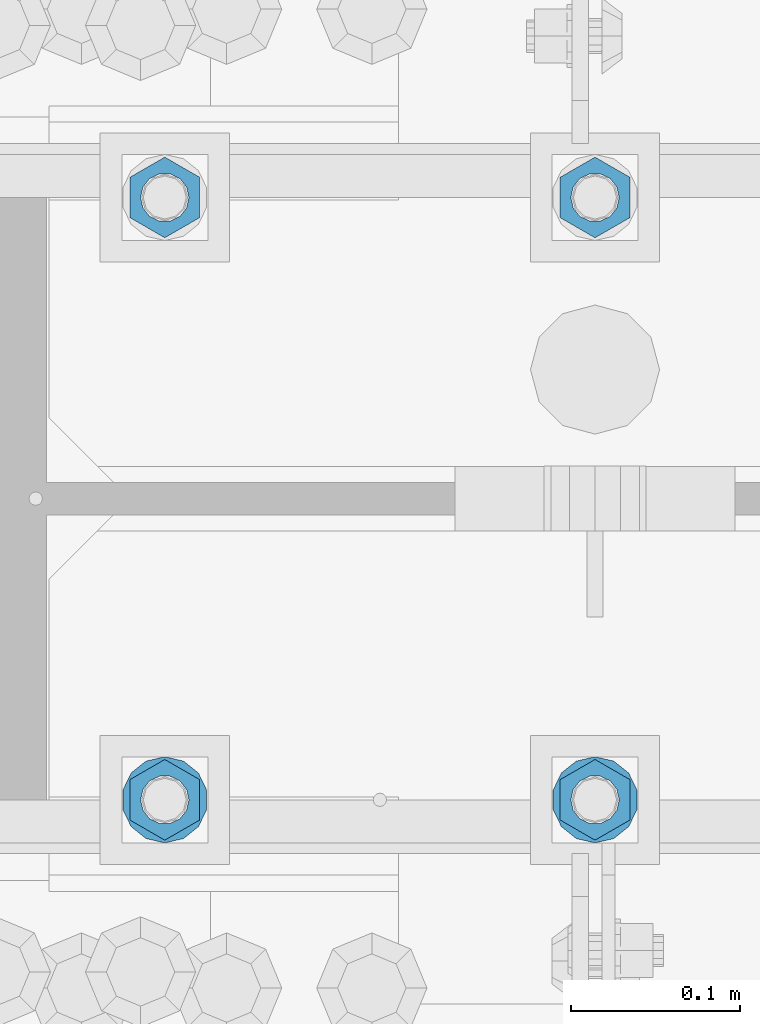
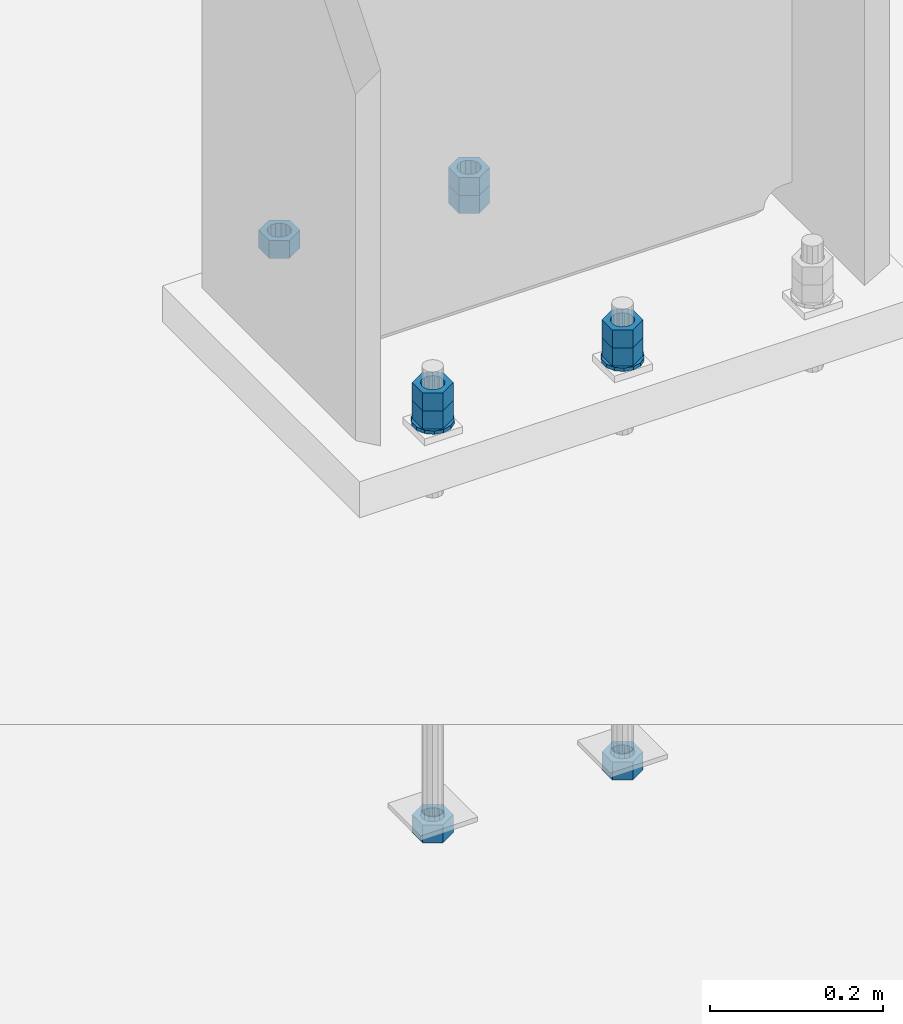
# One storey, part 1025 of 1763: 11 columns, 1 element without a shape of its own.
"""IFC2X3 building model written with IfcOpenShell, lengths in millimetres."""

from ifc_helpers import new_model, si_unit, frame, origin_with_axes, place, context, subcontext, project, spatial, faceted_brep, material, type_object, element, aggregate, save


model = new_model("IFC2X3")

# Units and contexts
model_context = context("Model", 3, precision=1e-05, world=origin_with_axes())
body_context = subcontext(model_context, "Body", "Model", "MODEL_VIEW")
ifc_project = project(units=[si_unit("LENGTHUNIT", "METRE", prefix="MILLI"), si_unit("AREAUNIT", "SQUARE_METRE"), si_unit("VOLUMEUNIT", "CUBIC_METRE"), si_unit("MASSUNIT", "GRAM", prefix="KILO"), si_unit("TIMEUNIT", "SECOND"), si_unit("PLANEANGLEUNIT", "RADIAN"), si_unit("SOLIDANGLEUNIT", "STERADIAN"), si_unit("THERMODYNAMICTEMPERATUREUNIT", "DEGREE_CELSIUS"), si_unit("LUMINOUSINTENSITYUNIT", "LUMEN")], contexts=[model_context])

# Site, building, storey
site_placement = place(None, origin_with_axes())
site = spatial("IfcSite", under=ifc_project, at=site_placement, CompositionType="ELEMENT")
building_placement = place(site_placement, origin_with_axes())
building = spatial("IfcBuilding", under=site, at=building_placement, Name="Undefined", CompositionType="ELEMENT")
storey_placement = place(building_placement, origin_with_axes())
storey = spatial("IfcBuildingStorey", under=building, at=storey_placement, Name="Undefined", CompositionType="ELEMENT", Elevation=0.0)

# Assembly, columns
assembly_placement = place(storey_placement, origin_with_axes())
assembly = element("IfcElementAssembly", 1, at=assembly_placement, inside=storey, Name="TEMPLATE", AssemblyPlace="NOTDEFINED", PredefinedType="RIGID_FRAME")
ifc_material_1 = material(Name="STEEL/A563")
column_type_1 = type_object("IfcColumnType", Name="1_HEAVY_HEX_NUT", PredefinedType="NOTDEFINED")
column_1_placement = place(assembly_placement, frame((-49402.4372736984, 51943.0, -150.812499999999), z_axis=(1.0, 0.0, 0.0), x_axis=(0.0, 0.0, -1.0)))
column_1 = element("IfcColumn", 2, at=column_1_placement, type_object=column_type_1, material=ifc_material_1, Name="NUT", ObjectType="1_HEAVY_HEX_NUT", context=body_context, shape_type="Brep", body=[
    faceted_brep([(0.0, -23.8099994659424, 0.0), (0.0, -11.9099998474121, -20.6200008392334), (25.4, -11.9099998474121, -20.6200008392334), (25.4, -23.8099994659424, 0.0), (0.0, 11.9099998474121, -20.6200008392334), (25.4, 11.9099998474121, -20.6200008392334), (0.0, 23.8099994659424, 0.0), (25.4, 23.8099994659424, 0.0), (0.0, 11.9099998474121, 20.6200008392334), (25.4, 11.9099998474121, 20.6200008392334), (0.0, -11.9099998474121, 20.6200008392334), (25.4, -11.9099998474121, 20.6200008392334), (0.0, 0.0, 14.289999961853), (0.0, 6.20019861543551, 12.8748450879575), (25.4, 6.20019861543551, 12.8748450879502), (25.4, 0.0, 14.289999961853), (0.0, 11.1723718546418, 8.90966924477834), (25.4, 11.1723718546418, 8.90966924477834), (0.0, 13.9317198278877, 3.17982413774735), (25.4, 13.9317198278877, 3.17982413774007), (0.0, 13.9317198278877, -3.17982413774735), (25.4, 13.9317198278877, -3.17982413774007), (0.0, 11.1723718546418, -8.90966924477834), (25.4, 11.1723718546418, -8.90966924477834), (0.0, 6.20019861543551, -12.8748450879575), (25.4, 6.20019861543551, -12.8748450879502), (0.0, 0.0, -14.289999961853), (25.4, 0.0, -14.289999961853), (0.0, -6.20019861543551, -12.8748450879575), (25.4, -6.20019861543551, -12.8748450879502), (0.0, -11.1723718546418, -8.90966924477834), (25.4, -11.1723718546418, -8.90966924477834), (0.0, -13.9317198278877, -3.17982413774735), (25.4, -13.9317198278877, -3.17982413774007), (0.0, -13.9317198278877, 3.17982413774735), (25.4, -13.9317198278877, 3.17982413774007), (0.0, -11.1723718546418, 8.90966924477834), (25.4, -11.1723718546418, 8.90966924477834), (0.0, -6.20019861543551, 12.8748450879575), (25.4, -6.20019861543551, 12.8748450879502)], [[[0, 1, 2, 3]], [[1, 4, 5, 2]], [[4, 6, 7, 5]], [[6, 8, 9, 7]], [[8, 10, 11, 9]], [[10, 0, 3, 11]], [[12, 13, 14, 15]], [[13, 16, 17, 14]], [[16, 18, 19, 17]], [[18, 20, 21, 19]], [[20, 22, 23, 21]], [[22, 24, 25, 23]], [[24, 26, 27, 25]], [[26, 28, 29, 27]], [[28, 30, 31, 29]], [[30, 32, 33, 31]], [[32, 34, 35, 33]], [[34, 36, 37, 35]], [[36, 38, 39, 37]], [[38, 12, 15, 39]], [[5, 7, 9, 11, 3, 2], [17, 19, 21, 23, 25, 27, 29, 31, 33, 35, 37, 39, 15, 14]], [[10, 8, 6, 4, 1, 0], [38, 36, 34, 32, 30, 28, 26, 24, 22, 20, 18, 16, 13, 12]]]),
])
column_2_placement = place(assembly_placement, frame((-49402.4372736984, 52298.6, -150.812499999999), z_axis=(-1.0, 0.0, 0.0), x_axis=(0.0, 0.0, -1.0)))
column_2 = element("IfcColumn", 3, at=column_2_placement, type_object=column_type_1, material=ifc_material_1, Name="NUT", ObjectType="1_HEAVY_HEX_NUT", context=body_context, shape_type="Brep", body=[
    faceted_brep([(0.0, -23.8099994659424, 0.0), (0.0, -11.9099998474121, -20.6200008392334), (25.4, -11.9099998474121, -20.6200008392334), (25.4, -23.8099994659424, 0.0), (0.0, 11.9099998474121, -20.6200008392334), (25.4, 11.9099998474121, -20.6200008392334), (0.0, 23.8099994659424, 0.0), (25.4, 23.8099994659424, 0.0), (0.0, 11.9099998474121, 20.6200008392334), (25.4, 11.9099998474121, 20.6200008392334), (0.0, -11.9099998474121, 20.6200008392334), (25.4, -11.9099998474121, 20.6200008392334), (0.0, 0.0, 14.289999961853), (0.0, 6.20019861543551, 12.8748450879575), (25.4, 6.20019861543551, 12.8748450879502), (25.4, 0.0, 14.289999961853), (0.0, 11.1723718546418, 8.90966924477834), (25.4, 11.1723718546418, 8.90966924477834), (0.0, 13.9317198278877, 3.17982413774735), (25.4, 13.9317198278877, 3.17982413774007), (0.0, 13.9317198278877, -3.17982413774735), (25.4, 13.9317198278877, -3.17982413774007), (0.0, 11.1723718546418, -8.90966924477834), (25.4, 11.1723718546418, -8.90966924477834), (0.0, 6.20019861543551, -12.8748450879575), (25.4, 6.20019861543551, -12.8748450879502), (0.0, 0.0, -14.289999961853), (25.4, 0.0, -14.289999961853), (0.0, -6.20019861543551, -12.8748450879575), (25.4, -6.20019861543551, -12.8748450879502), (0.0, -11.1723718546418, -8.90966924477834), (25.4, -11.1723718546418, -8.90966924477834), (0.0, -13.9317198278877, -3.17982413774735), (25.4, -13.9317198278877, -3.17982413774007), (0.0, -13.9317198278877, 3.17982413774735), (25.4, -13.9317198278877, 3.17982413774007), (0.0, -11.1723718546418, 8.90966924477834), (25.4, -11.1723718546418, 8.90966924477834), (0.0, -6.20019861543551, 12.8748450879575), (25.4, -6.20019861543551, 12.8748450879502)], [[[0, 1, 2, 3]], [[1, 4, 5, 2]], [[4, 6, 7, 5]], [[6, 8, 9, 7]], [[8, 10, 11, 9]], [[10, 0, 3, 11]], [[12, 13, 14, 15]], [[13, 16, 17, 14]], [[16, 18, 19, 17]], [[18, 20, 21, 19]], [[20, 22, 23, 21]], [[22, 24, 25, 23]], [[24, 26, 27, 25]], [[26, 28, 29, 27]], [[28, 30, 31, 29]], [[30, 32, 33, 31]], [[32, 34, 35, 33]], [[34, 36, 37, 35]], [[36, 38, 39, 37]], [[38, 12, 15, 39]], [[5, 7, 9, 11, 3, 2], [17, 19, 21, 23, 25, 27, 29, 31, 33, 35, 37, 39, 15, 14]], [[10, 8, 6, 4, 1, 0], [38, 36, 34, 32, 30, 28, 26, 24, 22, 20, 18, 16, 13, 12]]]),
])
column_3_placement = place(assembly_placement, frame((-49656.4372736984, 51943.0, -150.812499999999), z_axis=(1.0, 0.0, 0.0), x_axis=(0.0, 0.0, -1.0)))
column_3 = element("IfcColumn", 4, at=column_3_placement, type_object=column_type_1, material=ifc_material_1, Name="NUT", ObjectType="1_HEAVY_HEX_NUT", context=body_context, shape_type="Brep", body=[
    faceted_brep([(0.0, -23.8099994659424, 0.0), (0.0, -11.9099998474121, -20.6200008392334), (25.4, -11.9099998474121, -20.6200008392334), (25.4, -23.8099994659424, 0.0), (0.0, 11.9099998474121, -20.6200008392334), (25.4, 11.9099998474121, -20.6200008392334), (0.0, 23.8099994659424, 0.0), (25.4, 23.8099994659424, 0.0), (0.0, 11.9099998474121, 20.6200008392334), (25.4, 11.9099998474121, 20.6200008392334), (0.0, -11.9099998474121, 20.6200008392334), (25.4, -11.9099998474121, 20.6200008392334), (0.0, 0.0, 14.289999961853), (0.0, 6.20019861543551, 12.8748450879575), (25.4, 6.20019861543551, 12.8748450879502), (25.4, 0.0, 14.289999961853), (0.0, 11.1723718546418, 8.90966924477834), (25.4, 11.1723718546418, 8.90966924477834), (0.0, 13.9317198278877, 3.17982413774735), (25.4, 13.9317198278877, 3.17982413774007), (0.0, 13.9317198278877, -3.17982413774735), (25.4, 13.9317198278877, -3.17982413774007), (0.0, 11.1723718546418, -8.90966924477834), (25.4, 11.1723718546418, -8.90966924477834), (0.0, 6.20019861543551, -12.8748450879575), (25.4, 6.20019861543551, -12.8748450879502), (0.0, 0.0, -14.289999961853), (25.4, 0.0, -14.289999961853), (0.0, -6.20019861543551, -12.8748450879575), (25.4, -6.20019861543551, -12.8748450879502), (0.0, -11.1723718546418, -8.90966924477834), (25.4, -11.1723718546418, -8.90966924477834), (0.0, -13.9317198278877, -3.17982413774735), (25.4, -13.9317198278877, -3.17982413774007), (0.0, -13.9317198278877, 3.17982413774735), (25.4, -13.9317198278877, 3.17982413774007), (0.0, -11.1723718546418, 8.90966924477834), (25.4, -11.1723718546418, 8.90966924477834), (0.0, -6.20019861543551, 12.8748450879575), (25.4, -6.20019861543551, 12.8748450879502)], [[[0, 1, 2, 3]], [[1, 4, 5, 2]], [[4, 6, 7, 5]], [[6, 8, 9, 7]], [[8, 10, 11, 9]], [[10, 0, 3, 11]], [[12, 13, 14, 15]], [[13, 16, 17, 14]], [[16, 18, 19, 17]], [[18, 20, 21, 19]], [[20, 22, 23, 21]], [[22, 24, 25, 23]], [[24, 26, 27, 25]], [[26, 28, 29, 27]], [[28, 30, 31, 29]], [[30, 32, 33, 31]], [[32, 34, 35, 33]], [[34, 36, 37, 35]], [[36, 38, 39, 37]], [[38, 12, 15, 39]], [[5, 7, 9, 11, 3, 2], [17, 19, 21, 23, 25, 27, 29, 31, 33, 35, 37, 39, 15, 14]], [[10, 8, 6, 4, 1, 0], [38, 36, 34, 32, 30, 28, 26, 24, 22, 20, 18, 16, 13, 12]]]),
])
column_4_placement = place(assembly_placement, frame((-49656.4372736984, 52298.6, -150.812499999999), z_axis=(-1.0, 0.0, 0.0), x_axis=(0.0, 0.0, -1.0)))
column_4 = element("IfcColumn", 5, at=column_4_placement, type_object=column_type_1, material=ifc_material_1, Name="NUT", ObjectType="1_HEAVY_HEX_NUT", context=body_context, shape_type="Brep", body=[
    faceted_brep([(0.0, -23.8099994659424, 0.0), (0.0, -11.9099998474121, -20.6200008392334), (25.4, -11.9099998474121, -20.6200008392334), (25.4, -23.8099994659424, 0.0), (0.0, 11.9099998474121, -20.6200008392334), (25.4, 11.9099998474121, -20.6200008392334), (0.0, 23.8099994659424, 0.0), (25.4, 23.8099994659424, 0.0), (0.0, 11.9099998474121, 20.6200008392334), (25.4, 11.9099998474121, 20.6200008392334), (0.0, -11.9099998474121, 20.6200008392334), (25.4, -11.9099998474121, 20.6200008392334), (0.0, 0.0, 14.289999961853), (0.0, 6.20019861543551, 12.8748450879575), (25.4, 6.20019861543551, 12.8748450879502), (25.4, 0.0, 14.289999961853), (0.0, 11.1723718546418, 8.90966924477834), (25.4, 11.1723718546418, 8.90966924477834), (0.0, 13.9317198278877, 3.17982413774735), (25.4, 13.9317198278877, 3.17982413774007), (0.0, 13.9317198278877, -3.17982413774735), (25.4, 13.9317198278877, -3.17982413774007), (0.0, 11.1723718546418, -8.90966924477834), (25.4, 11.1723718546418, -8.90966924477834), (0.0, 6.20019861543551, -12.8748450879575), (25.4, 6.20019861543551, -12.8748450879502), (0.0, 0.0, -14.289999961853), (25.4, 0.0, -14.289999961853), (0.0, -6.20019861543551, -12.8748450879575), (25.4, -6.20019861543551, -12.8748450879502), (0.0, -11.1723718546418, -8.90966924477834), (25.4, -11.1723718546418, -8.90966924477834), (0.0, -13.9317198278877, -3.17982413774735), (25.4, -13.9317198278877, -3.17982413774007), (0.0, -13.9317198278877, 3.17982413774735), (25.4, -13.9317198278877, 3.17982413774007), (0.0, -11.1723718546418, 8.90966924477834), (25.4, -11.1723718546418, 8.90966924477834), (0.0, -6.20019861543551, 12.8748450879575), (25.4, -6.20019861543551, 12.8748450879502)], [[[0, 1, 2, 3]], [[1, 4, 5, 2]], [[4, 6, 7, 5]], [[6, 8, 9, 7]], [[8, 10, 11, 9]], [[10, 0, 3, 11]], [[12, 13, 14, 15]], [[13, 16, 17, 14]], [[16, 18, 19, 17]], [[18, 20, 21, 19]], [[20, 22, 23, 21]], [[22, 24, 25, 23]], [[24, 26, 27, 25]], [[26, 28, 29, 27]], [[28, 30, 31, 29]], [[30, 32, 33, 31]], [[32, 34, 35, 33]], [[34, 36, 37, 35]], [[36, 38, 39, 37]], [[38, 12, 15, 39]], [[5, 7, 9, 11, 3, 2], [17, 19, 21, 23, 25, 27, 29, 31, 33, 35, 37, 39, 15, 14]], [[10, 8, 6, 4, 1, 0], [38, 36, 34, 32, 30, 28, 26, 24, 22, 20, 18, 16, 13, 12]]]),
])
column_5_placement = place(assembly_placement, frame((-49402.4372736984, 51943.0, -176.212499999999), z_axis=(1.0, 0.0, 0.0), x_axis=(0.0, 0.0, -1.0)))
column_5 = element("IfcColumn", 6, at=column_5_placement, type_object=column_type_1, material=ifc_material_1, Name="NUT", ObjectType="1_HEAVY_HEX_NUT", context=body_context, shape_type="Brep", body=[
    faceted_brep([(0.0, -23.8099994659424, 0.0), (0.0, -11.9099998474121, -20.6200008392334), (25.4, -11.9099998474121, -20.6200008392334), (25.4, -23.8099994659424, 0.0), (0.0, 11.9099998474121, -20.6200008392334), (25.4, 11.9099998474121, -20.6200008392334), (0.0, 23.8099994659424, 0.0), (25.4, 23.8099994659424, 0.0), (0.0, 11.9099998474121, 20.6200008392334), (25.4, 11.9099998474121, 20.6200008392334), (0.0, -11.9099998474121, 20.6200008392334), (25.4, -11.9099998474121, 20.6200008392334), (0.0, 0.0, 14.289999961853), (0.0, 6.20019861543551, 12.8748450879575), (25.4, 6.20019861543551, 12.8748450879502), (25.4, 0.0, 14.289999961853), (0.0, 11.1723718546418, 8.90966924477834), (25.4, 11.1723718546418, 8.90966924477834), (0.0, 13.9317198278877, 3.17982413774735), (25.4, 13.9317198278877, 3.17982413774007), (0.0, 13.9317198278877, -3.17982413774735), (25.4, 13.9317198278877, -3.17982413774007), (0.0, 11.1723718546418, -8.90966924477834), (25.4, 11.1723718546418, -8.90966924477834), (0.0, 6.20019861543551, -12.8748450879575), (25.4, 6.20019861543551, -12.8748450879502), (0.0, 0.0, -14.289999961853), (25.4, 0.0, -14.289999961853), (0.0, -6.20019861543551, -12.8748450879575), (25.4, -6.20019861543551, -12.8748450879502), (0.0, -11.1723718546418, -8.90966924477834), (25.4, -11.1723718546418, -8.90966924477834), (0.0, -13.9317198278877, -3.17982413774735), (25.4, -13.9317198278877, -3.17982413774007), (0.0, -13.9317198278877, 3.17982413774735), (25.4, -13.9317198278877, 3.17982413774007), (0.0, -11.1723718546418, 8.90966924477834), (25.4, -11.1723718546418, 8.90966924477834), (0.0, -6.20019861543551, 12.8748450879575), (25.4, -6.20019861543551, 12.8748450879502)], [[[0, 1, 2, 3]], [[1, 4, 5, 2]], [[4, 6, 7, 5]], [[6, 8, 9, 7]], [[8, 10, 11, 9]], [[10, 0, 3, 11]], [[12, 13, 14, 15]], [[13, 16, 17, 14]], [[16, 18, 19, 17]], [[18, 20, 21, 19]], [[20, 22, 23, 21]], [[22, 24, 25, 23]], [[24, 26, 27, 25]], [[26, 28, 29, 27]], [[28, 30, 31, 29]], [[30, 32, 33, 31]], [[32, 34, 35, 33]], [[34, 36, 37, 35]], [[36, 38, 39, 37]], [[38, 12, 15, 39]], [[5, 7, 9, 11, 3, 2], [17, 19, 21, 23, 25, 27, 29, 31, 33, 35, 37, 39, 15, 14]], [[10, 8, 6, 4, 1, 0], [38, 36, 34, 32, 30, 28, 26, 24, 22, 20, 18, 16, 13, 12]]]),
])
column_6_placement = place(assembly_placement, frame((-49402.4372736984, 51943.0, -761.999999999999), z_axis=(1.0, 0.0, 0.0), x_axis=(0.0, 0.0, -1.0)))
column_6 = element("IfcColumn", 7, at=column_6_placement, type_object=column_type_1, material=ifc_material_1, Name="NUT", ObjectType="1_HEAVY_HEX_NUT", context=body_context, shape_type="Brep", body=[
    faceted_brep([(0.0, -23.8099994659424, 0.0), (0.0, -11.9099998474121, -20.6200008392334), (25.4, -11.9099998474121, -20.6200008392334), (25.4, -23.8099994659424, 0.0), (0.0, 11.9099998474121, -20.6200008392334), (25.4, 11.9099998474121, -20.6200008392334), (0.0, 23.8099994659424, 0.0), (25.4, 23.8099994659424, 0.0), (0.0, 11.9099998474121, 20.6200008392334), (25.4, 11.9099998474121, 20.6200008392334), (0.0, -11.9099998474121, 20.6200008392334), (25.4, -11.9099998474121, 20.6200008392334), (0.0, 0.0, 14.289999961853), (0.0, 6.20019861543551, 12.8748450879575), (25.4, 6.20019861543551, 12.8748450879502), (25.4, 0.0, 14.289999961853), (0.0, 11.1723718546418, 8.90966924477834), (25.4, 11.1723718546418, 8.90966924477834), (0.0, 13.9317198278877, 3.17982413774735), (25.4, 13.9317198278877, 3.17982413774007), (0.0, 13.9317198278877, -3.17982413774735), (25.4, 13.9317198278877, -3.17982413774007), (0.0, 11.1723718546418, -8.90966924477834), (25.4, 11.1723718546418, -8.90966924477834), (0.0, 6.20019861543551, -12.8748450879575), (25.4, 6.20019861543551, -12.8748450879502), (0.0, 0.0, -14.289999961853), (25.4, 0.0, -14.289999961853), (0.0, -6.20019861543551, -12.8748450879575), (25.4, -6.20019861543551, -12.8748450879502), (0.0, -11.1723718546418, -8.90966924477834), (25.4, -11.1723718546418, -8.90966924477834), (0.0, -13.9317198278877, -3.17982413774735), (25.4, -13.9317198278877, -3.17982413774007), (0.0, -13.9317198278877, 3.17982413774735), (25.4, -13.9317198278877, 3.17982413774007), (0.0, -11.1723718546418, 8.90966924477834), (25.4, -11.1723718546418, 8.90966924477834), (0.0, -6.20019861543551, 12.8748450879575), (25.4, -6.20019861543551, 12.8748450879502)], [[[0, 1, 2, 3]], [[1, 4, 5, 2]], [[4, 6, 7, 5]], [[6, 8, 9, 7]], [[8, 10, 11, 9]], [[10, 0, 3, 11]], [[12, 13, 14, 15]], [[13, 16, 17, 14]], [[16, 18, 19, 17]], [[18, 20, 21, 19]], [[20, 22, 23, 21]], [[22, 24, 25, 23]], [[24, 26, 27, 25]], [[26, 28, 29, 27]], [[28, 30, 31, 29]], [[30, 32, 33, 31]], [[32, 34, 35, 33]], [[34, 36, 37, 35]], [[36, 38, 39, 37]], [[38, 12, 15, 39]], [[5, 7, 9, 11, 3, 2], [17, 19, 21, 23, 25, 27, 29, 31, 33, 35, 37, 39, 15, 14]], [[10, 8, 6, 4, 1, 0], [38, 36, 34, 32, 30, 28, 26, 24, 22, 20, 18, 16, 13, 12]]]),
])
column_7_placement = place(assembly_placement, frame((-49402.4372736984, 52298.6, -176.212499999999), z_axis=(-1.0, 0.0, 0.0), x_axis=(0.0, 0.0, -1.0)))
column_7 = element("IfcColumn", 8, at=column_7_placement, type_object=column_type_1, material=ifc_material_1, Name="NUT", ObjectType="1_HEAVY_HEX_NUT", context=body_context, shape_type="Brep", body=[
    faceted_brep([(0.0, -23.8099994659424, 0.0), (0.0, -11.9099998474121, -20.6200008392334), (25.4, -11.9099998474121, -20.6200008392334), (25.4, -23.8099994659424, 0.0), (0.0, 11.9099998474121, -20.6200008392334), (25.4, 11.9099998474121, -20.6200008392334), (0.0, 23.8099994659424, 0.0), (25.4, 23.8099994659424, 0.0), (0.0, 11.9099998474121, 20.6200008392334), (25.4, 11.9099998474121, 20.6200008392334), (0.0, -11.9099998474121, 20.6200008392334), (25.4, -11.9099998474121, 20.6200008392334), (0.0, 0.0, 14.289999961853), (0.0, 6.20019861543551, 12.8748450879575), (25.4, 6.20019861543551, 12.8748450879502), (25.4, 0.0, 14.289999961853), (0.0, 11.1723718546418, 8.90966924477834), (25.4, 11.1723718546418, 8.90966924477834), (0.0, 13.9317198278877, 3.17982413774735), (25.4, 13.9317198278877, 3.17982413774007), (0.0, 13.9317198278877, -3.17982413774735), (25.4, 13.9317198278877, -3.17982413774007), (0.0, 11.1723718546418, -8.90966924477834), (25.4, 11.1723718546418, -8.90966924477834), (0.0, 6.20019861543551, -12.8748450879575), (25.4, 6.20019861543551, -12.8748450879502), (0.0, 0.0, -14.289999961853), (25.4, 0.0, -14.289999961853), (0.0, -6.20019861543551, -12.8748450879575), (25.4, -6.20019861543551, -12.8748450879502), (0.0, -11.1723718546418, -8.90966924477834), (25.4, -11.1723718546418, -8.90966924477834), (0.0, -13.9317198278877, -3.17982413774735), (25.4, -13.9317198278877, -3.17982413774007), (0.0, -13.9317198278877, 3.17982413774735), (25.4, -13.9317198278877, 3.17982413774007), (0.0, -11.1723718546418, 8.90966924477834), (25.4, -11.1723718546418, 8.90966924477834), (0.0, -6.20019861543551, 12.8748450879575), (25.4, -6.20019861543551, 12.8748450879502)], [[[0, 1, 2, 3]], [[1, 4, 5, 2]], [[4, 6, 7, 5]], [[6, 8, 9, 7]], [[8, 10, 11, 9]], [[10, 0, 3, 11]], [[12, 13, 14, 15]], [[13, 16, 17, 14]], [[16, 18, 19, 17]], [[18, 20, 21, 19]], [[20, 22, 23, 21]], [[22, 24, 25, 23]], [[24, 26, 27, 25]], [[26, 28, 29, 27]], [[28, 30, 31, 29]], [[30, 32, 33, 31]], [[32, 34, 35, 33]], [[34, 36, 37, 35]], [[36, 38, 39, 37]], [[38, 12, 15, 39]], [[5, 7, 9, 11, 3, 2], [17, 19, 21, 23, 25, 27, 29, 31, 33, 35, 37, 39, 15, 14]], [[10, 8, 6, 4, 1, 0], [38, 36, 34, 32, 30, 28, 26, 24, 22, 20, 18, 16, 13, 12]]]),
])
column_8_placement = place(assembly_placement, frame((-49656.4372736984, 51943.0, -176.212499999999), z_axis=(1.0, 0.0, 0.0), x_axis=(0.0, 0.0, -1.0)))
column_8 = element("IfcColumn", 9, at=column_8_placement, type_object=column_type_1, material=ifc_material_1, Name="NUT", ObjectType="1_HEAVY_HEX_NUT", context=body_context, shape_type="Brep", body=[
    faceted_brep([(0.0, -23.8099994659424, 0.0), (0.0, -11.9099998474121, -20.6200008392334), (25.4, -11.9099998474121, -20.6200008392334), (25.4, -23.8099994659424, 0.0), (0.0, 11.9099998474121, -20.6200008392334), (25.4, 11.9099998474121, -20.6200008392334), (0.0, 23.8099994659424, 0.0), (25.4, 23.8099994659424, 0.0), (0.0, 11.9099998474121, 20.6200008392334), (25.4, 11.9099998474121, 20.6200008392334), (0.0, -11.9099998474121, 20.6200008392334), (25.4, -11.9099998474121, 20.6200008392334), (0.0, 0.0, 14.289999961853), (0.0, 6.20019861543551, 12.8748450879575), (25.4, 6.20019861543551, 12.8748450879502), (25.4, 0.0, 14.289999961853), (0.0, 11.1723718546418, 8.90966924477834), (25.4, 11.1723718546418, 8.90966924477834), (0.0, 13.9317198278877, 3.17982413774735), (25.4, 13.9317198278877, 3.17982413774007), (0.0, 13.9317198278877, -3.17982413774735), (25.4, 13.9317198278877, -3.17982413774007), (0.0, 11.1723718546418, -8.90966924477834), (25.4, 11.1723718546418, -8.90966924477834), (0.0, 6.20019861543551, -12.8748450879575), (25.4, 6.20019861543551, -12.8748450879502), (0.0, 0.0, -14.289999961853), (25.4, 0.0, -14.289999961853), (0.0, -6.20019861543551, -12.8748450879575), (25.4, -6.20019861543551, -12.8748450879502), (0.0, -11.1723718546418, -8.90966924477834), (25.4, -11.1723718546418, -8.90966924477834), (0.0, -13.9317198278877, -3.17982413774735), (25.4, -13.9317198278877, -3.17982413774007), (0.0, -13.9317198278877, 3.17982413774735), (25.4, -13.9317198278877, 3.17982413774007), (0.0, -11.1723718546418, 8.90966924477834), (25.4, -11.1723718546418, 8.90966924477834), (0.0, -6.20019861543551, 12.8748450879575), (25.4, -6.20019861543551, 12.8748450879502)], [[[0, 1, 2, 3]], [[1, 4, 5, 2]], [[4, 6, 7, 5]], [[6, 8, 9, 7]], [[8, 10, 11, 9]], [[10, 0, 3, 11]], [[12, 13, 14, 15]], [[13, 16, 17, 14]], [[16, 18, 19, 17]], [[18, 20, 21, 19]], [[20, 22, 23, 21]], [[22, 24, 25, 23]], [[24, 26, 27, 25]], [[26, 28, 29, 27]], [[28, 30, 31, 29]], [[30, 32, 33, 31]], [[32, 34, 35, 33]], [[34, 36, 37, 35]], [[36, 38, 39, 37]], [[38, 12, 15, 39]], [[5, 7, 9, 11, 3, 2], [17, 19, 21, 23, 25, 27, 29, 31, 33, 35, 37, 39, 15, 14]], [[10, 8, 6, 4, 1, 0], [38, 36, 34, 32, 30, 28, 26, 24, 22, 20, 18, 16, 13, 12]]]),
])
column_9_placement = place(assembly_placement, frame((-49656.4372736984, 51943.0, -761.999999999999), z_axis=(1.0, 0.0, 0.0), x_axis=(0.0, 0.0, -1.0)))
column_9 = element("IfcColumn", 10, at=column_9_placement, type_object=column_type_1, material=ifc_material_1, Name="NUT", ObjectType="1_HEAVY_HEX_NUT", context=body_context, shape_type="Brep", body=[
    faceted_brep([(0.0, -23.8099994659424, 0.0), (0.0, -11.9099998474121, -20.6200008392334), (25.4, -11.9099998474121, -20.6200008392334), (25.4, -23.8099994659424, 0.0), (0.0, 11.9099998474121, -20.6200008392334), (25.4, 11.9099998474121, -20.6200008392334), (0.0, 23.8099994659424, 0.0), (25.4, 23.8099994659424, 0.0), (0.0, 11.9099998474121, 20.6200008392334), (25.4, 11.9099998474121, 20.6200008392334), (0.0, -11.9099998474121, 20.6200008392334), (25.4, -11.9099998474121, 20.6200008392334), (0.0, 0.0, 14.289999961853), (0.0, 6.20019861543551, 12.8748450879575), (25.4, 6.20019861543551, 12.8748450879502), (25.4, 0.0, 14.289999961853), (0.0, 11.1723718546418, 8.90966924477834), (25.4, 11.1723718546418, 8.90966924477834), (0.0, 13.9317198278877, 3.17982413774735), (25.4, 13.9317198278877, 3.17982413774007), (0.0, 13.9317198278877, -3.17982413774735), (25.4, 13.9317198278877, -3.17982413774007), (0.0, 11.1723718546418, -8.90966924477834), (25.4, 11.1723718546418, -8.90966924477834), (0.0, 6.20019861543551, -12.8748450879575), (25.4, 6.20019861543551, -12.8748450879502), (0.0, 0.0, -14.289999961853), (25.4, 0.0, -14.289999961853), (0.0, -6.20019861543551, -12.8748450879575), (25.4, -6.20019861543551, -12.8748450879502), (0.0, -11.1723718546418, -8.90966924477834), (25.4, -11.1723718546418, -8.90966924477834), (0.0, -13.9317198278877, -3.17982413774735), (25.4, -13.9317198278877, -3.17982413774007), (0.0, -13.9317198278877, 3.17982413774735), (25.4, -13.9317198278877, 3.17982413774007), (0.0, -11.1723718546418, 8.90966924477834), (25.4, -11.1723718546418, 8.90966924477834), (0.0, -6.20019861543551, 12.8748450879575), (25.4, -6.20019861543551, 12.8748450879502)], [[[0, 1, 2, 3]], [[1, 4, 5, 2]], [[4, 6, 7, 5]], [[6, 8, 9, 7]], [[8, 10, 11, 9]], [[10, 0, 3, 11]], [[12, 13, 14, 15]], [[13, 16, 17, 14]], [[16, 18, 19, 17]], [[18, 20, 21, 19]], [[20, 22, 23, 21]], [[22, 24, 25, 23]], [[24, 26, 27, 25]], [[26, 28, 29, 27]], [[28, 30, 31, 29]], [[30, 32, 33, 31]], [[32, 34, 35, 33]], [[34, 36, 37, 35]], [[36, 38, 39, 37]], [[38, 12, 15, 39]], [[5, 7, 9, 11, 3, 2], [17, 19, 21, 23, 25, 27, 29, 31, 33, 35, 37, 39, 15, 14]], [[10, 8, 6, 4, 1, 0], [38, 36, 34, 32, 30, 28, 26, 24, 22, 20, 18, 16, 13, 12]]]),
])
ifc_material_2 = material(Name="STEEL/F436")
column_type_2 = type_object("IfcColumnType", Name="1_WASHER", PredefinedType="NOTDEFINED")
column_10_placement = place(assembly_placement, frame((-49402.4372736984, 51943.0, -201.612499999999), z_axis=(1.0, 0.0, 0.0), x_axis=(0.0, 0.0, -1.0)))
column_10 = element("IfcColumn", 11, at=column_10_placement, type_object=column_type_2, material=ifc_material_2, Name="WASHER", ObjectType="1_WASHER", context=body_context, shape_type="Brep", body=[
    faceted_brep([(0.0, -25.4000000000015, 0.0), (0.0, -22.8846089010258, -11.0206468080723), (4.76249999999982, -22.8846089010258, -11.0206468080723), (4.76249999999982, -25.3999996185303, 0.0), (0.0, -15.8366407293724, -19.8585193564359), (4.76249999999982, -15.8366407293724, -19.8585193564359), (0.0, -5.65203163760452, -24.7631685975066), (4.76249999999982, -5.65203163760452, -24.7631685975066), (0.0, 5.65203163760452, -24.7631685975066), (4.76249999999982, 5.65203163760452, -24.7631685975066), (0.0, 15.8366407293724, -19.8585193564359), (4.76249999999982, 15.8366407293724, -19.8585193564359), (0.0, 22.8846089010258, -11.0206468080723), (4.76249999999982, 22.8846089010258, -11.0206468080723), (0.0, 25.4000000000015, 0.0), (4.76249999999982, 25.3999996185303, 0.0), (0.0, 22.8846089010258, 11.0206468080723), (4.76249999999982, 22.8846089010258, 11.0206468080723), (0.0, 15.8366407293724, 19.8585193564359), (4.76249999999982, 15.8366407293724, 19.8585193564359), (0.0, 5.65203163760452, 24.7631685975066), (4.76249999999982, 5.65203163760452, 24.7631685975066), (0.0, -5.65203163760452, 24.7631685975066), (4.76249999999982, -5.65203163760452, 24.7631685975066), (0.0, -15.8366407293724, 19.8585193564359), (4.76249999999982, -15.8366407293724, 19.8585193564359), (0.0, -22.8846089010258, 11.0206468080723), (4.76249999999982, -22.8846089010258, 11.0206468080723), (0.0, 0.0, 14.289999961853), (0.0, 6.20019861543551, 12.8748450879575), (4.76249999999982, 6.20019861543551, 12.8748450879502), (4.76249999999982, 0.0, 14.289999961853), (0.0, 11.1723718546418, 8.90966924477834), (4.76249999999982, 11.1723718546418, 8.90966924477834), (0.0, 13.9317198278877, 3.17982413774735), (4.76249999999982, 13.9317198278877, 3.17982413774007), (0.0, 13.9317198278877, -3.17982413774735), (4.76249999999982, 13.9317198278877, -3.17982413774007), (0.0, 11.1723718546418, -8.90966924477834), (4.76249999999982, 11.1723718546418, -8.90966924477834), (0.0, 6.20019861543551, -12.8748450879575), (4.76249999999982, 6.20019861543551, -12.8748450879502), (0.0, 0.0, -14.289999961853), (4.76249999999982, 0.0, -14.289999961853), (0.0, -6.20019861543551, -12.8748450879575), (4.76249999999982, -6.20019861543551, -12.8748450879502), (0.0, -11.1723718546418, -8.90966924477834), (4.76249999999982, -11.1723718546418, -8.90966924477834), (0.0, -13.9317198278877, -3.17982413774735), (4.76249999999982, -13.9317198278877, -3.17982413774007), (0.0, -13.9317198278877, 3.17982413774735), (4.76249999999982, -13.9317198278877, 3.17982413774007), (0.0, -11.1723718546418, 8.90966924477834), (4.76249999999982, -11.1723718546418, 8.90966924477834), (0.0, -6.20019861543551, 12.8748450879575), (4.76249999999982, -6.20019861543551, 12.8748450879502)], [[[0, 1, 2, 3]], [[1, 4, 5, 2]], [[4, 6, 7, 5]], [[6, 8, 9, 7]], [[8, 10, 11, 9]], [[10, 12, 13, 11]], [[12, 14, 15, 13]], [[14, 16, 17, 15]], [[16, 18, 19, 17]], [[18, 20, 21, 19]], [[20, 22, 23, 21]], [[22, 24, 25, 23]], [[24, 26, 27, 25]], [[26, 0, 3, 27]], [[28, 29, 30, 31]], [[29, 32, 33, 30]], [[32, 34, 35, 33]], [[34, 36, 37, 35]], [[36, 38, 39, 37]], [[38, 40, 41, 39]], [[40, 42, 43, 41]], [[42, 44, 45, 43]], [[44, 46, 47, 45]], [[46, 48, 49, 47]], [[48, 50, 51, 49]], [[50, 52, 53, 51]], [[52, 54, 55, 53]], [[54, 28, 31, 55]], [[5, 7, 9, 11, 13, 15, 17, 19, 21, 23, 25, 27, 3, 2], [33, 35, 37, 39, 41, 43, 45, 47, 49, 51, 53, 55, 31, 30]], [[26, 24, 22, 20, 18, 16, 14, 12, 10, 8, 6, 4, 1, 0], [54, 52, 50, 48, 46, 44, 42, 40, 38, 36, 34, 32, 29, 28]]]),
])
column_11_placement = place(assembly_placement, frame((-49656.4372736984, 51943.0, -201.612499999999), z_axis=(1.0, 0.0, 0.0), x_axis=(0.0, 0.0, -1.0)))
column_11 = element("IfcColumn", 12, at=column_11_placement, type_object=column_type_2, material=ifc_material_2, Name="WASHER", ObjectType="1_WASHER", context=body_context, shape_type="Brep", body=[
    faceted_brep([(0.0, -25.4000000000015, 0.0), (0.0, -22.8846089010258, -11.0206468080723), (4.76249999999982, -22.8846089010258, -11.0206468080723), (4.76249999999982, -25.3999996185303, 0.0), (0.0, -15.8366407293724, -19.8585193564359), (4.76249999999982, -15.8366407293724, -19.8585193564359), (0.0, -5.65203163760452, -24.7631685975066), (4.76249999999982, -5.65203163760452, -24.7631685975066), (0.0, 5.65203163760452, -24.7631685975066), (4.76249999999982, 5.65203163760452, -24.7631685975066), (0.0, 15.8366407293724, -19.8585193564359), (4.76249999999982, 15.8366407293724, -19.8585193564359), (0.0, 22.8846089010258, -11.0206468080723), (4.76249999999982, 22.8846089010258, -11.0206468080723), (0.0, 25.4000000000015, 0.0), (4.76249999999982, 25.3999996185303, 0.0), (0.0, 22.8846089010258, 11.0206468080723), (4.76249999999982, 22.8846089010258, 11.0206468080723), (0.0, 15.8366407293724, 19.8585193564359), (4.76249999999982, 15.8366407293724, 19.8585193564359), (0.0, 5.65203163760452, 24.7631685975066), (4.76249999999982, 5.65203163760452, 24.7631685975066), (0.0, -5.65203163760452, 24.7631685975066), (4.76249999999982, -5.65203163760452, 24.7631685975066), (0.0, -15.8366407293724, 19.8585193564359), (4.76249999999982, -15.8366407293724, 19.8585193564359), (0.0, -22.8846089010258, 11.0206468080723), (4.76249999999982, -22.8846089010258, 11.0206468080723), (0.0, 0.0, 14.289999961853), (0.0, 6.20019861543551, 12.8748450879575), (4.76249999999982, 6.20019861543551, 12.8748450879502), (4.76249999999982, 0.0, 14.289999961853), (0.0, 11.1723718546418, 8.90966924477834), (4.76249999999982, 11.1723718546418, 8.90966924477834), (0.0, 13.9317198278877, 3.17982413774735), (4.76249999999982, 13.9317198278877, 3.17982413774007), (0.0, 13.9317198278877, -3.17982413774735), (4.76249999999982, 13.9317198278877, -3.17982413774007), (0.0, 11.1723718546418, -8.90966924477834), (4.76249999999982, 11.1723718546418, -8.90966924477834), (0.0, 6.20019861543551, -12.8748450879575), (4.76249999999982, 6.20019861543551, -12.8748450879502), (0.0, 0.0, -14.289999961853), (4.76249999999982, 0.0, -14.289999961853), (0.0, -6.20019861543551, -12.8748450879575), (4.76249999999982, -6.20019861543551, -12.8748450879502), (0.0, -11.1723718546418, -8.90966924477834), (4.76249999999982, -11.1723718546418, -8.90966924477834), (0.0, -13.9317198278877, -3.17982413774735), (4.76249999999982, -13.9317198278877, -3.17982413774007), (0.0, -13.9317198278877, 3.17982413774735), (4.76249999999982, -13.9317198278877, 3.17982413774007), (0.0, -11.1723718546418, 8.90966924477834), (4.76249999999982, -11.1723718546418, 8.90966924477834), (0.0, -6.20019861543551, 12.8748450879575), (4.76249999999982, -6.20019861543551, 12.8748450879502)], [[[0, 1, 2, 3]], [[1, 4, 5, 2]], [[4, 6, 7, 5]], [[6, 8, 9, 7]], [[8, 10, 11, 9]], [[10, 12, 13, 11]], [[12, 14, 15, 13]], [[14, 16, 17, 15]], [[16, 18, 19, 17]], [[18, 20, 21, 19]], [[20, 22, 23, 21]], [[22, 24, 25, 23]], [[24, 26, 27, 25]], [[26, 0, 3, 27]], [[28, 29, 30, 31]], [[29, 32, 33, 30]], [[32, 34, 35, 33]], [[34, 36, 37, 35]], [[36, 38, 39, 37]], [[38, 40, 41, 39]], [[40, 42, 43, 41]], [[42, 44, 45, 43]], [[44, 46, 47, 45]], [[46, 48, 49, 47]], [[48, 50, 51, 49]], [[50, 52, 53, 51]], [[52, 54, 55, 53]], [[54, 28, 31, 55]], [[5, 7, 9, 11, 13, 15, 17, 19, 21, 23, 25, 27, 3, 2], [33, 35, 37, 39, 41, 43, 45, 47, 49, 51, 53, 55, 31, 30]], [[26, 24, 22, 20, 18, 16, 14, 12, 10, 8, 6, 4, 1, 0], [54, 52, 50, 48, 46, 44, 42, 40, 38, 36, 34, 32, 29, 28]]]),
])
aggregate(assembly, [column_1, column_2, column_3, column_4, column_5, column_10, column_6, column_7, column_8, column_11, column_9])

save(model, "model.ifc")
